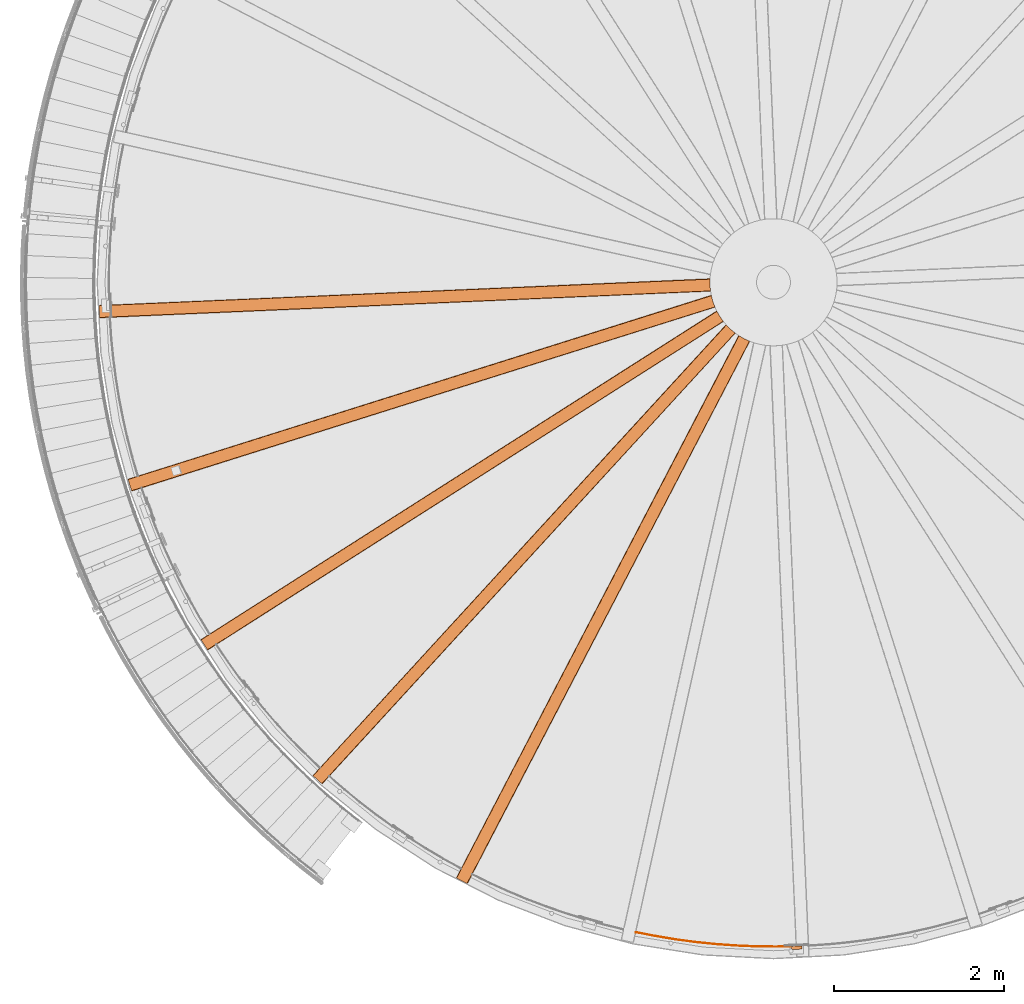
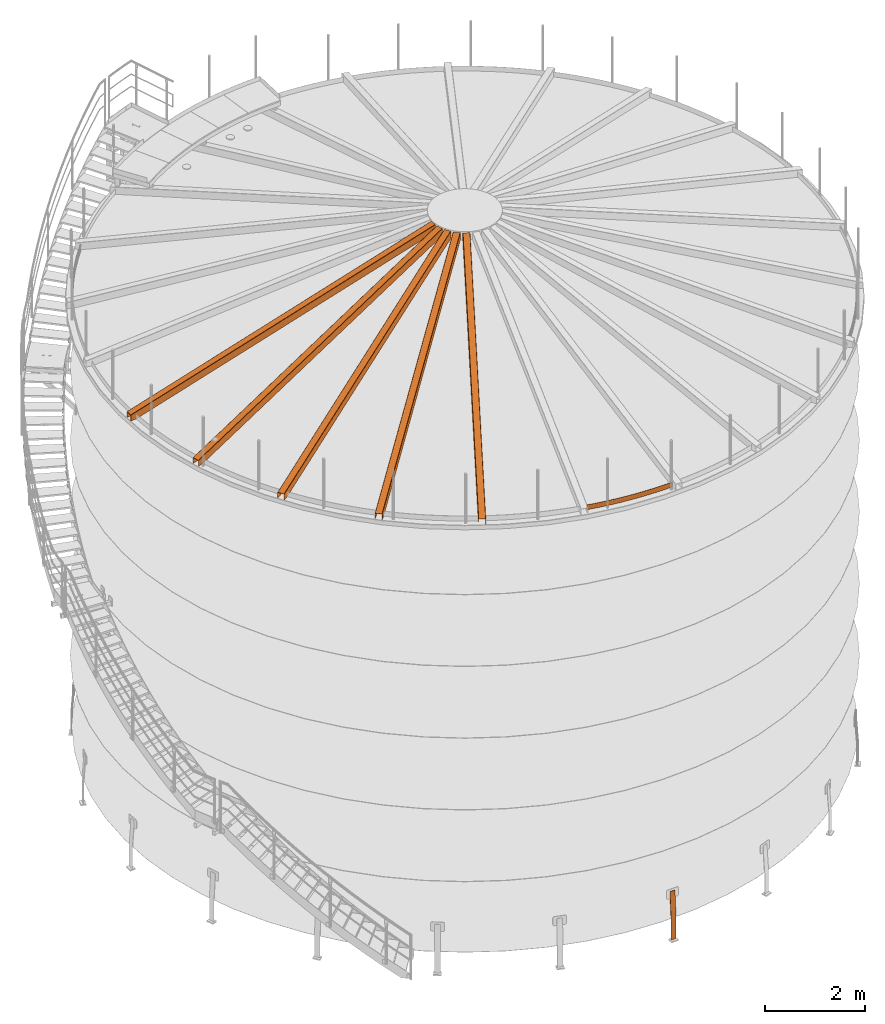
# One storey, part 15 of 126: 7 proxies.
"""IFC2X3 building model written with IfcOpenShell, lengths in millimetres."""

import ifcopenshell
import ifcopenshell.guid

model = None  # the IFC model being written
_history = None  # IfcOwnerHistory: only IFC2X3 demands one
_inside = {}  # id of a spatial element -> (the spatial element, [elements in it])
_under = {}  # id of a project, library or spatial element -> (it, [spatial elements below it])
_declared = {}  # id of a project -> (the project, [libraries it declares])
_typed = {}  # id of a type object -> (the type object, [elements of that type])
_made_of = {}  # id of a material, layer set ... -> (it, [elements and type objects made of it])


def new_model(schema):
    """Start an empty IFC model of exactly this schema.

    Asked for "IFC4X3", IfcOpenShell would pick the latest addendum, in which some entities
    have other attributes; the version numbers below select the first issue.
    IFC2X3 requires an IfcOwnerHistory on every rooted entity: one is made here for all.
    """
    global model, _history
    if schema == "IFC4X3":
        model = ifcopenshell.file(schema_version=(4, 3, 0, 0))
    else:
        model = ifcopenshell.file(schema=schema)
    _inside.clear()
    _under.clear()
    _declared.clear()
    _typed.clear()
    _made_of.clear()
    _history = None
    if model.schema == "IFC2X3":
        org = make("IfcOrganization", Name="unknown")
        user = make(
            "IfcPersonAndOrganization",
            ThePerson=make("IfcPerson", FamilyName="unknown"),
            TheOrganization=org,
        )
        app = make(
            "IfcApplication",
            ApplicationDeveloper=org,
            Version="unknown",
            ApplicationFullName="unknown",
            ApplicationIdentifier="unknown",
        )
        _history = make(
            "IfcOwnerHistory",
            OwningUser=user,
            OwningApplication=app,
            ChangeAction="ADDED",
            CreationDate=0,
        )
    return model


def make(cls, **values):
    """One entity of the class cls with the attributes given. An attribute that is None is left unset."""
    return model.create_entity(
        cls, **{name: value for name, value in values.items() if value is not None}
    )


def rooted(cls, **values):
    """An entity with a GlobalId (a new one), such as an element, a storey or a relation."""
    return make(cls, GlobalId=ifcopenshell.guid.new(), OwnerHistory=_history, **values)


def si_unit(unit_type, name, prefix=None):
    """IfcSIUnit, for example si_unit("LENGTHUNIT", "METRE", prefix="MILLI")."""
    return make("IfcSIUnit", UnitType=unit_type, Prefix=prefix, Name=name)


def assignment(units):
    """IfcUnitAssignment: the units of a project."""
    return None if units is None else make("IfcUnitAssignment", Units=units)


def point(xyz):
    """IfcCartesianPoint."""
    return None if xyz is None else make("IfcCartesianPoint", Coordinates=xyz)


def direction(xyz):
    """IfcDirection."""
    return None if xyz is None else make("IfcDirection", DirectionRatios=xyz)


def frame(location, z_axis=None, x_axis=None):
    """IfcAxis2Placement3D, a coordinate frame: its origin and axes. An axis left out is left unset."""
    return make(
        "IfcAxis2Placement3D",
        Location=point(location),
        Axis=direction(z_axis),
        RefDirection=direction(x_axis),
    )


def origin():
    """The frame at (0, 0, 0) with its axes left unset."""
    return frame((0.0, 0.0, 0.0))


def origin_with_axes():
    """The frame at (0, 0, 0) with the z axis (0, 0, 1) and the x axis (1, 0, 0) written out."""
    return frame((0.0, 0.0, 0.0), z_axis=(0.0, 0.0, 1.0), x_axis=(1.0, 0.0, 0.0))


def place(relative_to, where):
    """IfcLocalPlacement: puts the frame where relative to a parent placement (None: the world)."""
    return make(
        "IfcLocalPlacement", PlacementRelTo=relative_to, RelativePlacement=where
    )


def context(
    kind, dimensions, precision=None, world=None, true_north=None, identifier=None
):
    """IfcGeometricRepresentationContext, for example the 3D "Model" context."""
    return make(
        "IfcGeometricRepresentationContext",
        ContextIdentifier=identifier,
        ContextType=kind,
        CoordinateSpaceDimension=dimensions,
        Precision=precision,
        WorldCoordinateSystem=world,
        TrueNorth=true_north,
    )


def project(units=None, contexts=None):
    """IfcProject with its units and contexts."""
    return rooted(
        "IfcProject",
        Name="project",
        RepresentationContexts=contexts,
        UnitsInContext=assignment(units),
    )


def spatial(cls, under=None, at=None, **own):
    """A site, building, storey or space (cls), placed at a placement, below another one or the project."""
    s = rooted(cls, ObjectPlacement=at, **own)
    if under is not None:
        _under.setdefault(under.id(), (under, []))[1].append(s)
    return s


def faces_of(points, faces, orient=None, outer=None):
    """IfcFace entities. A face is a list of loops; a loop is a list of indices into points, from 0.

    orient and outer hold one flag for each loop. By default every Orientation is true, the
    first loop of a face is its IfcFaceOuterBound and the others are IfcFaceBound.
    """
    made = []
    for i, loops in enumerate(faces):
        bounds = []
        for j, loop in enumerate(loops):
            is_outer = j == 0 if outer is None else outer[i][j]
            bounds.append(
                make(
                    "IfcFaceOuterBound" if is_outer else "IfcFaceBound",
                    Bound=make("IfcPolyLoop", Polygon=[points[k] for k in loop]),
                    Orientation=True if orient is None else orient[i][j],
                )
            )
        made.append(make("IfcFace", Bounds=bounds))
    return made


def faceted_brep(points, faces, orient=None, outer=None, voids=None):
    """IfcFacetedBrep: a solid bounded by flat faces; with voids (closed shells), ...WithVoids."""
    shared = [point(p) for p in points]
    hull = make("IfcClosedShell", CfsFaces=faces_of(shared, faces, orient, outer))
    if voids is None:
        return make("IfcFacetedBrep", Outer=hull)
    return make(
        "IfcFacetedBrepWithVoids",
        Outer=hull,
        Voids=[
            make(cls, CfsFaces=faces_of(shared, fs, o, b)) for cls, fs, o, b in voids
        ],
    )


def shape(context_of_items, identifier, shape_type, items):
    """IfcShapeRepresentation: the items that make up one representation, for example the "Body"."""
    return make(
        "IfcShapeRepresentation",
        ContextOfItems=context_of_items,
        RepresentationIdentifier=identifier,
        RepresentationType=shape_type,
        Items=items,
    )


def material(Name=None, Category=None):
    """IfcMaterial."""
    return make("IfcMaterial", Name=Name, Category=Category)


def made_of(thing, what):
    """Note that an element or type object is made of a material, layer set ...; save() writes the relation."""
    if what is not None:
        _made_of.setdefault(what.id(), (what, []))[1].append(thing)
    return thing


def element(
    cls,
    number,
    at=None,
    inside=None,
    cuts=None,
    type_object=None,
    material=None,
    context=None,
    identifier="Body",
    shape_type=None,
    held_by="IfcProductDefinitionShape",
    body=None,
    shapes=None,
    **own,
):
    """One element of the class cls, such as IfcWall. Its Tag is "e" and its number.

    at: its placement. inside: the storey or other place that contains it. cuts: it is an
    opening in that element (IfcRelVoidsElement). A single representation is given by context,
    identifier, shape_type and body (its items); several are given by shapes. held_by: the class
    of the entity that holds the representations. save() writes the other relations.
    """
    e = rooted(cls, Tag="e%d" % number, ObjectPlacement=at, **own)
    if body is not None:
        shapes = [shape(context, identifier, shape_type, body)]
    if shapes is not None:
        e.Representation = make(held_by, Representations=shapes)
    if inside is not None:
        _inside.setdefault(inside.id(), (inside, []))[1].append(e)
    if cuts is not None:
        rooted(
            "IfcRelVoidsElement", RelatingBuildingElement=cuts, RelatedOpeningElement=e
        )
    if type_object is not None:
        _typed.setdefault(type_object.id(), (type_object, []))[1].append(e)
    return made_of(e, material)


def aggregate(whole, parts):
    """IfcRelAggregates: a whole, such as a stair, and the parts it consists of."""
    return rooted("IfcRelAggregates", RelatingObject=whole, RelatedObjects=parts)


def save(model, path):
    """Write the relations noted so far, then the file.

    IfcRelAggregates (storeys below a building ...), IfcRelContainedInSpatialStructure (elements
    in a storey), IfcRelDefinesByType, IfcRelAssociatesMaterial and IfcRelDeclares: one each for
    every whole, place, type object, material and project.
    """
    for whole, parts in _under.values():
        aggregate(whole, parts)
    for where, things in _inside.values():
        rooted(
            "IfcRelContainedInSpatialStructure",
            RelatedElements=things,
            RelatingStructure=where,
        )
    for kind, things in _typed.values():
        rooted("IfcRelDefinesByType", RelatedObjects=things, RelatingType=kind)
    for what, things in _made_of.values():
        rooted("IfcRelAssociatesMaterial", RelatedObjects=things, RelatingMaterial=what)
    for by, libraries in _declared.values():
        rooted("IfcRelDeclares", RelatingContext=by, RelatedDefinitions=libraries)
    model.write(path)


model = new_model("IFC2X3")

# Units and contexts
context_of_model_1 = context(None, 3, precision=0.1, world=origin())
context_of_model_2 = context(None, 3, precision=0.1, world=origin())
ifc_project = project(units=[si_unit("LENGTHUNIT", "METRE", prefix="MILLI"), si_unit("AREAUNIT", "SQUARE_METRE", prefix="CENTI"), si_unit("VOLUMEUNIT", "CUBIC_METRE", prefix="CENTI"), si_unit("MASSUNIT", "GRAM", prefix="KILO")], contexts=[context_of_model_1, context_of_model_2])

# Site, building, storey
site_placement = place(None, origin_with_axes())
site = spatial("IfcSite", under=ifc_project, at=site_placement, CompositionType="ELEMENT")
building_placement = place(site_placement, origin_with_axes())
building = spatial("IfcBuilding", under=site, at=building_placement, CompositionType="ELEMENT")
storey_placement = place(building_placement, origin_with_axes())
storey = spatial("IfcBuildingStorey", under=building, at=storey_placement, CompositionType="ELEMENT")

# Proxies
ifc_material = material(Name="STAHL")
proxy_1_placement = place(storey_placement, origin_with_axes())
element("IfcBuildingElementProxy", 1, at=proxy_1_placement, inside=storey, material=ifc_material, Name="profile", context=context_of_model_2, shape_type="Brep", body=[
    faceted_brep([(8224.3, 173.1, 654.1), (8224.0, 181.1, 654.1), (8221.6, 181.0, 651.1), (8221.8, 173.0, 651.1), (8219.7, 180.9, 647.7), (8220.0, 172.9, 647.7), (8218.6, 180.9, 643.9), (8218.9, 172.9, 643.9), (8219.8, 134.9, -500.0), (8219.8, 134.9, 0.0), (8218.5, 172.9, 540.0), (8218.5, 172.9, 640.0), (8218.2, 180.9, 640.0), (8218.2, 180.9, 540.0), (8219.5, 142.9, 0.0), (8219.5, 142.9, -500.0), (8334.7, 185.0, 651.1), (8332.3, 184.9, 654.1), (8332.5, 176.9, 654.1), (8335.0, 177.0, 651.1), (8336.9, 177.0, 647.7), (8336.6, 185.0, 647.7), (8338.0, 177.1, 643.9), (8337.7, 185.1, 643.9), (8339.7, 139.1, 0.0), (8339.7, 139.1, -500.0), (8339.4, 147.1, -500.0), (8339.4, 147.1, 0.0), (8338.1, 185.1, 540.0), (8338.1, 185.1, 640.0), (8338.4, 177.1, 640.0), (8338.4, 177.1, 540.0), (8234.6, 173.4, 659.6), (8238.5, 173.6, 660.0), (8318.4, 176.4, 660.0), (8322.3, 176.5, 659.6), (8322.0, 184.5, 659.6), (8318.1, 184.4, 660.0), (8238.2, 181.6, 660.0), (8234.3, 181.4, 659.6), (8325.8, 184.6, 658.5), (8326.1, 176.6, 658.5), (8329.2, 184.8, 656.6), (8329.5, 176.8, 656.6), (8230.8, 173.3, 658.5), (8230.5, 181.3, 658.5), (8227.3, 173.2, 656.6), (8227.1, 181.2, 656.6)], [[[0, 1, 2, 3]], [[3, 2, 4, 5]], [[5, 4, 6, 7]], [[8, 9, 10, 11, 7, 6, 12, 13, 14, 15]], [[16, 17, 18, 19]], [[16, 19, 20, 21]], [[21, 20, 22, 23]], [[24, 25, 26, 27, 28, 29, 23, 22, 30, 31]], [[32, 33, 34, 35, 36, 37, 38, 39]], [[40, 36, 35, 41]], [[42, 40, 41, 43]], [[42, 43, 18, 17]], [[44, 32, 39, 45]], [[46, 44, 45, 47]], [[0, 46, 47, 1]], [[9, 8, 25, 24, 31, 30, 22, 20, 19, 18, 43, 41, 35, 34, 33, 32, 44, 46, 0, 3, 5, 7, 11, 10]], [[14, 13, 12, 6, 4, 2, 1, 47, 45, 39, 38, 37, 36, 40, 42, 17, 16, 21, 23, 29, 28, 27, 26, 15]], [[26, 25, 8, 15]]]),
])
proxy_2_placement = place(storey_placement, origin_with_axes())
element("IfcBuildingElementProxy", 2, at=proxy_2_placement, inside=storey, material=ifc_material, Name="profile", context=context_of_model_2, shape_type="Brep", body=[
    faceted_brep([(7262.6, 7898.5, 12406.2), (7262.0, 7902.5, 12406.1), (7262.0, 7902.5, 12573.8), (7262.0, 7902.6, 12574.5), (7262.0, 7902.7, 12575.2), (7262.0, 7903.1, 12576.0), (7261.9, 7903.5, 12576.6), (7261.8, 7904.1, 12577.1), (7261.7, 7904.7, 12577.5), (7261.6, 7905.5, 12577.8), (7261.5, 7906.5, 12577.9), (7255.7, 7972.3, 12577.1), (7255.8, 8040.4, 12577.9), (7255.9, 8040.8, 12577.9), (7255.9, 8041.2, 12577.8), (7255.9, 8042.1, 12577.6), (7256.0, 8042.8, 12577.1), (7256.0, 8043.4, 12576.5), (7256.0, 8043.9, 12575.8), (7256.0, 8044.2, 12574.9), (7256.0, 8044.4, 12573.9), (7256.0, 8044.4, 12406.2), (7256.3, 8048.4, 12406.3), (7256.3, 8048.4, 12574.0), (7256.2, 8048.3, 12575.4), (7256.2, 8047.9, 12576.8), (7256.2, 8047.2, 12578.2), (7256.1, 8046.3, 12579.5), (7256.1, 8045.2, 12580.5), (7256.0, 8043.9, 12581.3), (7255.9, 8042.2, 12581.9), (7255.8, 8040.4, 12582.1), (7255.7, 7972.3, 12581.2), (7261.5, 7906.5, 12582.0), (7261.6, 7905.6, 12582.0), (7261.7, 7904.7, 12581.8), (7262.0, 7903.1, 12581.3), (7262.2, 7901.6, 12580.4), (7262.3, 7900.4, 12579.2), (7262.5, 7899.5, 12577.8), (7262.6, 7898.8, 12576.0), (7262.6, 7898.5, 12573.9), (55.8, 7583.9, 10506.0), (55.8, 7583.9, 10641.0), (55.8, 7584.0, 10642.6), (55.8, 7584.5, 10644.2), (55.7, 7585.4, 10645.9), (55.7, 7586.7, 10647.3), (55.6, 7588.2, 10648.4), (55.5, 7590.0, 10649.1), (55.5, 7591.9, 10649.3), (49.6, 7725.7, 10649.3), (49.5, 7727.3, 10649.2), (49.5, 7728.8, 10648.7), (49.4, 7730.4, 10647.7), (49.3, 7731.8, 10646.4), (49.3, 7732.8, 10644.8), (49.3, 7733.5, 10643.0), (49.3, 7733.7, 10641.0), (49.3, 7733.7, 10506.0), (49.4, 7729.7, 10506.0), (49.4, 7729.7, 10641.0), (49.4, 7729.6, 10641.8), (49.4, 7729.4, 10642.6), (49.5, 7729.0, 10643.5), (49.5, 7728.3, 10644.2), (49.5, 7727.5, 10644.7), (49.6, 7726.7, 10645.1), (49.6, 7725.7, 10645.2), (55.5, 7591.9, 10645.2), (55.5, 7591.1, 10645.1), (55.5, 7590.3, 10644.9), (55.6, 7589.5, 10644.4), (55.6, 7588.8, 10643.7), (55.6, 7588.3, 10642.9), (55.6, 7588.0, 10642.0), (55.6, 7587.9, 10641.0), (55.6, 7587.9, 10506.0), (171.3, 7735.0, 10506.0), (171.1, 7739.0, 10506.0), (177.7, 7589.2, 10506.0), (177.5, 7593.2, 10506.0)], [[[0, 1, 2, 3, 4, 5, 6, 7, 8, 9, 10, 11, 12, 13, 14, 15, 16, 17, 18, 19, 20, 21, 22, 23, 24, 25, 26, 27, 28, 29, 30, 31, 32, 33, 34, 35, 36, 37, 38, 39, 40, 41]], [[42, 43, 44, 45, 46, 47, 48, 49, 50, 51, 52, 53, 54, 55, 56, 57, 58, 59, 60, 61, 62, 63, 64, 65, 66, 67, 68, 69, 70, 71, 72, 73, 74, 75, 76, 77]], [[21, 78, 79, 22]], [[57, 24, 23, 22, 79, 59, 58]], [[56, 26, 25, 24, 57]], [[26, 56, 55, 27]], [[27, 55, 54, 28]], [[29, 28, 54, 53]], [[30, 29, 53, 52]], [[49, 35, 34, 33, 32, 31, 30, 52, 51, 50]], [[36, 35, 49, 48]], [[37, 36, 48, 47]], [[38, 37, 47, 46]], [[39, 38, 46, 45]], [[40, 39, 45, 44]], [[43, 42, 80, 0, 41, 40, 44]], [[1, 0, 80, 81]], [[77, 81, 80, 42]], [[60, 59, 79, 78]], [[62, 61, 60, 78, 21, 20, 19]], [[19, 18, 63, 62]], [[18, 17, 64, 63]], [[17, 16, 65, 64]], [[16, 15, 66, 65]], [[15, 14, 67, 66]], [[70, 69, 68, 67, 14, 13, 12, 11, 10, 9]], [[9, 8, 71, 70]], [[8, 7, 72, 71]], [[6, 73, 72, 7]], [[5, 74, 73, 6]], [[75, 74, 5, 4, 3]], [[77, 76, 75, 3, 2, 1, 81]]]),
])
proxy_3_placement = place(storey_placement, origin_with_axes())
element("IfcBuildingElementProxy", 3, at=proxy_3_placement, inside=storey, material=ifc_material, Name="profile", context=context_of_model_2, shape_type="Brep", body=[
    faceted_brep([(7315.5, 7710.0, 12406.2), (7313.9, 7713.7, 12406.1), (7313.9, 7713.7, 12573.8), (7313.9, 7713.8, 12574.5), (7313.8, 7713.9, 12575.2), (7313.7, 7714.2, 12576.0), (7313.5, 7714.7, 12576.6), (7313.3, 7715.2, 12577.1), (7313.0, 7715.8, 12577.5), (7312.7, 7716.5, 12577.8), (7312.3, 7717.4, 12577.9), (7289.7, 7779.5, 12577.1), (7272.2, 7845.3, 12577.9), (7272.1, 7845.7, 12577.9), (7272.0, 7846.1, 12577.8), (7271.8, 7846.9, 12577.6), (7271.7, 7847.7, 12577.1), (7271.6, 7848.2, 12576.5), (7271.5, 7848.7, 12575.8), (7271.4, 7849.1, 12574.9), (7271.4, 7849.2, 12573.9), (7271.4, 7849.2, 12406.2), (7270.5, 7853.1, 12406.3), (7270.5, 7853.1, 12574.0), (7270.6, 7853.0, 12575.4), (7270.6, 7852.6, 12576.8), (7270.8, 7852.0, 12578.2), (7271.0, 7851.1, 12579.5), (7271.2, 7850.0, 12580.5), (7271.5, 7848.7, 12581.3), (7271.8, 7847.1, 12581.9), (7272.2, 7845.3, 12582.1), (7289.7, 7779.5, 12581.2), (7312.3, 7717.4, 12582.0), (7312.7, 7716.6, 12582.0), (7313.0, 7715.7, 12581.8), (7313.7, 7714.2, 12581.3), (7314.2, 7712.9, 12580.4), (7314.7, 7711.8, 12579.2), (7315.1, 7710.9, 12577.8), (7315.4, 7710.2, 12576.0), (7315.5, 7710.0, 12573.9), (435.7, 5540.8, 10506.0), (435.7, 5540.8, 10641.0), (435.6, 5541.0, 10642.6), (435.5, 5541.4, 10644.2), (435.2, 5542.3, 10645.9), (434.8, 5543.5, 10647.3), (434.4, 5545.0, 10648.4), (433.8, 5546.7, 10649.1), (433.3, 5548.4, 10649.3), (393.0, 5676.2, 10649.3), (392.5, 5677.7, 10649.2), (392.0, 5679.2, 10648.7), (391.6, 5680.7, 10647.7), (391.1, 5682.0, 10646.4), (390.8, 5683.0, 10644.8), (390.6, 5683.7, 10643.0), (390.6, 5683.9, 10641.0), (390.6, 5683.9, 10506.0), (391.8, 5680.0, 10506.0), (391.8, 5680.0, 10641.0), (391.8, 5680.0, 10641.8), (391.9, 5679.8, 10642.6), (392.0, 5679.3, 10643.5), (392.2, 5678.7, 10644.2), (392.4, 5678.0, 10644.7), (392.7, 5677.1, 10645.1), (393.0, 5676.2, 10645.2), (433.3, 5548.4, 10645.2), (433.5, 5547.7, 10645.1), (433.7, 5547.0, 10644.9), (434.0, 5546.2, 10644.4), (434.2, 5545.5, 10643.7), (434.3, 5545.0, 10642.9), (434.4, 5544.7, 10642.0), (434.5, 5544.6, 10641.0), (434.5, 5544.6, 10506.0), (508.1, 5716.7, 10506.0), (506.9, 5720.5, 10506.0), (552.0, 5577.5, 10506.0), (550.8, 5581.3, 10506.0)], [[[0, 1, 2, 3, 4, 5, 6, 7, 8, 9, 10, 11, 12, 13, 14, 15, 16, 17, 18, 19, 20, 21, 22, 23, 24, 25, 26, 27, 28, 29, 30, 31, 32, 33, 34, 35, 36, 37, 38, 39, 40, 41]], [[42, 43, 44, 45, 46, 47, 48, 49, 50, 51, 52, 53, 54, 55, 56, 57, 58, 59, 60, 61, 62, 63, 64, 65, 66, 67, 68, 69, 70, 71, 72, 73, 74, 75, 76, 77]], [[21, 78, 79, 22]], [[57, 24, 23, 22, 79, 59, 58]], [[56, 26, 25, 24, 57]], [[26, 56, 55, 27]], [[27, 55, 54, 28]], [[29, 28, 54, 53]], [[30, 29, 53, 52]], [[49, 35, 34, 33, 32, 31, 30, 52, 51, 50]], [[36, 35, 49, 48]], [[37, 36, 48, 47]], [[38, 37, 47, 46]], [[39, 38, 46, 45]], [[40, 39, 45, 44]], [[43, 42, 80, 0, 41, 40, 44]], [[1, 0, 80, 81]], [[77, 81, 80, 42]], [[60, 59, 79, 78]], [[62, 61, 60, 78, 21, 20, 19]], [[19, 18, 63, 62]], [[18, 17, 64, 63]], [[17, 16, 65, 64]], [[16, 15, 66, 65]], [[15, 14, 67, 66]], [[70, 69, 68, 67, 14, 13, 12, 11, 10, 9]], [[9, 8, 71, 70]], [[8, 7, 72, 71]], [[6, 73, 72, 7]], [[5, 74, 73, 6]], [[75, 74, 5, 4, 3]], [[77, 76, 75, 3, 2, 1, 81]]]),
])
proxy_4_placement = place(storey_placement, origin_with_axes())
element("IfcBuildingElementProxy", 4, at=proxy_4_placement, inside=storey, material=ifc_material, Name="profile", context=context_of_model_2, shape_type="Brep", body=[
    faceted_brep([(7415.3, 7541.6, 12573.9), (7415.3, 7541.6, 12406.2), (7412.8, 7544.7, 12406.1), (7412.8, 7544.7, 12573.8), (7412.8, 7544.8, 12574.5), (7412.7, 7544.9, 12575.2), (7412.5, 7545.2, 12576.0), (7412.2, 7545.6, 12576.6), (7411.9, 7546.0, 12577.1), (7411.4, 7546.5, 12577.5), (7410.9, 7547.2, 12577.8), (7410.4, 7547.9, 12577.9), (7372.5, 7602.0, 12577.1), (7338.5, 7661.0, 12577.9), (7338.3, 7661.4, 12577.9), (7338.1, 7661.8, 12577.8), (7337.7, 7662.6, 12577.6), (7337.4, 7663.2, 12577.1), (7337.1, 7663.8, 12576.5), (7336.9, 7664.2, 12575.8), (7336.8, 7664.5, 12574.9), (7336.7, 7664.6, 12573.9), (7336.7, 7664.6, 12406.2), (7334.9, 7668.2, 12406.3), (7334.9, 7668.2, 12574.0), (7334.9, 7668.1, 12575.4), (7335.1, 7667.8, 12576.8), (7335.4, 7667.2, 12578.2), (7335.8, 7666.3, 12579.5), (7336.3, 7665.4, 12580.5), (7336.9, 7664.2, 12581.3), (7337.7, 7662.7, 12581.9), (7338.5, 7661.0, 12582.1), (7372.5, 7602.0, 12581.2), (7410.4, 7547.9, 12582.0), (7410.9, 7547.2, 12582.0), (7411.5, 7546.5, 12581.8), (7412.5, 7545.2, 12581.3), (7413.4, 7544.0, 12580.4), (7414.1, 7543.1, 12579.2), (7414.7, 7542.3, 12577.8), (7415.1, 7541.8, 12576.0), (1331.4, 3665.7, 10506.0), (1331.4, 3665.7, 10641.0), (1331.3, 3665.8, 10642.6), (1331.0, 3666.2, 10644.2), (1330.5, 3667.0, 10645.9), (1329.9, 3668.0, 10647.3), (1329.0, 3669.4, 10648.4), (1328.1, 3670.9, 10649.1), (1327.1, 3672.4, 10649.3), (1255.1, 3785.4, 10649.3), (1254.2, 3786.8, 10649.2), (1253.4, 3788.0, 10648.7), (1252.5, 3789.4, 10647.7), (1251.8, 3790.6, 10646.4), (1251.2, 3791.5, 10644.8), (1250.9, 3792.0, 10643.0), (1250.8, 3792.2, 10641.0), (1250.8, 3792.2, 10506.0), (1252.9, 3788.8, 10506.0), (1252.9, 3788.8, 10641.0), (1253.0, 3788.8, 10641.8), (1253.1, 3788.6, 10642.6), (1253.3, 3788.2, 10643.5), (1253.7, 3787.6, 10644.2), (1254.1, 3787.0, 10644.7), (1254.6, 3786.2, 10645.1), (1255.1, 3785.4, 10645.2), (1327.1, 3672.4, 10645.2), (1327.5, 3671.8, 10645.1), (1327.9, 3671.1, 10644.9), (1328.3, 3670.4, 10644.4), (1328.7, 3669.9, 10643.7), (1329.0, 3669.4, 10642.9), (1329.2, 3669.2, 10642.0), (1329.2, 3669.1, 10641.0), (1329.2, 3669.1, 10506.0), (1355.8, 3854.4, 10506.0), (1353.6, 3857.7, 10506.0), (1434.2, 3731.2, 10506.0), (1432.1, 3734.6, 10506.0)], [[[0, 1, 2, 3, 4, 5, 6, 7, 8, 9, 10, 11, 12, 13, 14, 15, 16, 17, 18, 19, 20, 21, 22, 23, 24, 25, 26, 27, 28, 29, 30, 31, 32, 33, 34, 35, 36, 37, 38, 39, 40, 41]], [[42, 43, 44, 45, 46, 47, 48, 49, 50, 51, 52, 53, 54, 55, 56, 57, 58, 59, 60, 61, 62, 63, 64, 65, 66, 67, 68, 69, 70, 71, 72, 73, 74, 75, 76, 77]], [[22, 78, 79, 23]], [[57, 25, 24, 23, 79, 59, 58]], [[56, 27, 26, 25, 57]], [[27, 56, 55, 28]], [[28, 55, 54, 29]], [[30, 29, 54, 53]], [[31, 30, 53, 52]], [[49, 36, 35, 34, 33, 32, 31, 52, 51, 50]], [[37, 36, 49, 48]], [[38, 37, 48, 47]], [[39, 38, 47, 46]], [[40, 39, 46, 45]], [[41, 40, 45, 44]], [[43, 42, 80, 1, 0, 41, 44]], [[2, 1, 80, 81]], [[77, 81, 80, 42]], [[60, 59, 79, 78]], [[61, 60, 78, 22, 21, 20, 62]], [[20, 19, 63, 62]], [[19, 18, 64, 63]], [[18, 17, 65, 64]], [[17, 16, 66, 65]], [[16, 15, 67, 66]], [[70, 69, 68, 67, 15, 14, 13, 12, 11, 10]], [[10, 9, 71, 70]], [[9, 8, 72, 71]], [[7, 73, 72, 8]], [[6, 74, 73, 7]], [[75, 74, 6, 5, 4]], [[77, 76, 75, 4, 3, 2, 81]]]),
])
proxy_5_placement = place(storey_placement, origin_with_axes())
element("IfcBuildingElementProxy", 5, at=proxy_5_placement, inside=storey, material=ifc_material, Name="profile", context=context_of_model_2, shape_type="Brep", body=[
    faceted_brep([(7555.3, 7404.7, 12406.2), (7552.1, 7407.2, 12406.1), (7552.1, 7407.2, 12573.8), (7552.1, 7407.2, 12574.5), (7551.9, 7407.3, 12575.2), (7551.7, 7407.5, 12576.0), (7551.3, 7407.8, 12576.6), (7550.9, 7408.1, 12577.1), (7550.3, 7408.5, 12577.5), (7549.7, 7409.0, 12577.8), (7548.9, 7409.6, 12577.9), (7498.3, 7452.0, 12577.1), (7450.3, 7500.3, 12577.9), (7450.0, 7500.6, 12577.9), (7449.7, 7500.9, 12577.8), (7449.1, 7501.5, 12577.6), (7448.6, 7502.1, 12577.1), (7448.2, 7502.5, 12576.5), (7447.9, 7502.9, 12575.8), (7447.7, 7503.1, 12574.9), (7447.6, 7503.2, 12573.9), (7447.6, 7503.2, 12406.2), (7444.9, 7506.2, 12406.3), (7444.9, 7506.2, 12574.0), (7445.0, 7506.1, 12575.4), (7445.2, 7505.9, 12576.8), (7445.7, 7505.4, 12578.2), (7446.3, 7504.7, 12579.5), (7447.0, 7503.9, 12580.5), (7447.9, 7502.9, 12581.3), (7449.0, 7501.6, 12581.9), (7450.3, 7500.3, 12582.1), (7498.3, 7452.0, 12581.2), (7548.9, 7409.6, 12582.0), (7549.6, 7409.1, 12582.0), (7550.4, 7408.5, 12581.8), (7551.7, 7407.5, 12581.3), (7552.8, 7406.6, 12580.4), (7553.8, 7405.9, 12579.2), (7554.6, 7405.3, 12577.8), (7555.1, 7404.9, 12576.0), (7555.3, 7404.7, 12573.9), (2681.9, 2086.3, 10506.0), (2681.9, 2086.3, 10641.0), (2681.7, 2086.4, 10642.6), (2681.4, 2086.7, 10644.2), (2680.7, 2087.3, 10645.9), (2679.8, 2088.2, 10647.3), (2678.6, 2089.2, 10648.4), (2677.3, 2090.4, 10649.1), (2676.0, 2091.7, 10649.3), (2577.2, 2182.2, 10649.3), (2576.0, 2183.3, 10649.2), (2574.9, 2184.3, 10648.7), (2573.7, 2185.4, 10647.7), (2572.7, 2186.3, 10646.4), (2571.9, 2187.0, 10644.8), (2571.4, 2187.5, 10643.0), (2571.3, 2187.6, 10641.0), (2571.3, 2187.6, 10506.0), (2574.2, 2184.9, 10506.0), (2574.2, 2184.9, 10641.0), (2574.3, 2184.9, 10641.8), (2574.4, 2184.7, 10642.6), (2574.8, 2184.4, 10643.5), (2575.3, 2184.0, 10644.2), (2575.8, 2183.4, 10644.7), (2576.5, 2182.8, 10645.1), (2577.2, 2182.2, 10645.2), (2676.0, 2091.7, 10645.2), (2676.5, 2091.2, 10645.1), (2677.1, 2090.6, 10644.9), (2677.7, 2090.1, 10644.4), (2678.2, 2089.6, 10643.7), (2678.6, 2089.3, 10642.9), (2678.8, 2089.1, 10642.0), (2678.9, 2089.0, 10641.0), (2678.9, 2089.0, 10506.0), (2656.6, 2274.8, 10506.0), (2653.7, 2277.5, 10506.0), (2764.3, 2176.2, 10506.0), (2761.3, 2178.9, 10506.0)], [[[0, 1, 2, 3, 4, 5, 6, 7, 8, 9, 10, 11, 12, 13, 14, 15, 16, 17, 18, 19, 20, 21, 22, 23, 24, 25, 26, 27, 28, 29, 30, 31, 32, 33, 34, 35, 36, 37, 38, 39, 40, 41]], [[42, 43, 44, 45, 46, 47, 48, 49, 50, 51, 52, 53, 54, 55, 56, 57, 58, 59, 60, 61, 62, 63, 64, 65, 66, 67, 68, 69, 70, 71, 72, 73, 74, 75, 76, 77]], [[21, 78, 79, 22]], [[57, 24, 23, 22, 79, 59, 58]], [[55, 27, 26, 25, 24, 57, 56]], [[27, 55, 54, 28]], [[29, 28, 54, 53]], [[30, 29, 53, 52]], [[49, 35, 34, 33, 32, 31, 30, 52, 51, 50]], [[36, 35, 49, 48]], [[37, 36, 48, 47]], [[38, 37, 47, 46]], [[44, 40, 39, 38, 46, 45]], [[43, 42, 80, 0, 41, 40, 44]], [[1, 0, 80, 81]], [[77, 81, 80, 42]], [[60, 59, 79, 78]], [[61, 60, 78, 21, 20, 19, 62]], [[64, 63, 62, 19, 18, 17]], [[17, 16, 65, 64]], [[16, 15, 66, 65]], [[15, 14, 67, 66]], [[70, 69, 68, 67, 14, 13, 12, 11, 10, 9]], [[9, 8, 71, 70]], [[8, 7, 72, 71]], [[6, 73, 72, 7]], [[75, 74, 73, 6, 5, 4, 3]], [[77, 76, 75, 3, 2, 1, 81]]]),
])
proxy_6_placement = place(storey_placement, origin_with_axes())
element("IfcBuildingElementProxy", 6, at=proxy_6_placement, inside=storey, material=ifc_material, Name="profile", context=context_of_model_2, shape_type="Brep", body=[
    faceted_brep([(7726.0, 7308.8, 12573.9), (7726.0, 7308.8, 12406.2), (7722.3, 7310.3, 12406.1), (7722.3, 7310.3, 12573.8), (7722.2, 7310.3, 12574.5), (7722.1, 7310.4, 12575.2), (7721.8, 7310.5, 12576.0), (7721.3, 7310.7, 12576.6), (7720.8, 7310.9, 12577.1), (7720.2, 7311.2, 12577.5), (7719.4, 7311.5, 12577.8), (7718.6, 7311.8, 12577.9), (7658.7, 7339.7, 12577.1), (7599.8, 7373.9, 12577.9), (7599.4, 7374.1, 12577.9), (7599.0, 7374.4, 12577.8), (7598.4, 7374.8, 12577.6), (7597.7, 7375.2, 12577.1), (7597.2, 7375.5, 12576.5), (7596.8, 7375.8, 12575.8), (7596.5, 7376.0, 12574.9), (7596.4, 7376.1, 12573.9), (7596.4, 7376.1, 12406.2), (7593.1, 7378.3, 12406.3), (7593.1, 7378.3, 12574.0), (7593.2, 7378.2, 12575.4), (7593.5, 7378.0, 12576.8), (7594.0, 7377.6, 12578.2), (7594.8, 7377.1, 12579.5), (7595.7, 7376.5, 12580.5), (7596.8, 7375.8, 12581.3), (7598.2, 7374.9, 12581.9), (7599.8, 7373.9, 12582.1), (7658.7, 7339.7, 12581.2), (7718.6, 7311.8, 12582.0), (7719.4, 7311.5, 12582.0), (7720.2, 7311.2, 12581.8), (7721.8, 7310.5, 12581.3), (7723.1, 7310.0, 12580.4), (7724.2, 7309.5, 12579.2), (7725.1, 7309.2, 12577.8), (7725.8, 7308.9, 12576.0), (4395.1, 910.2, 10506.0), (4395.1, 910.2, 10641.0), (4395.0, 910.3, 10642.6), (4394.6, 910.5, 10644.2), (4393.8, 910.9, 10645.9), (4392.6, 911.5, 10647.3), (4391.2, 912.2, 10648.4), (4389.7, 913.1, 10649.1), (4388.0, 913.9, 10649.3), (4269.2, 975.8, 10649.3), (4267.8, 976.5, 10649.2), (4266.4, 977.2, 10648.7), (4265.0, 978.0, 10647.7), (4263.8, 978.6, 10646.4), (4262.8, 979.1, 10644.8), (4262.3, 979.4, 10643.0), (4262.1, 979.5, 10641.0), (4262.1, 979.5, 10506.0), (4265.6, 977.6, 10506.0), (4265.6, 977.6, 10641.0), (4265.7, 977.6, 10641.8), (4265.9, 977.5, 10642.6), (4266.3, 977.3, 10643.5), (4266.9, 977.0, 10644.2), (4267.6, 976.6, 10644.7), (4268.3, 976.2, 10645.1), (4269.2, 975.8, 10645.2), (4388.0, 913.9, 10645.2), (4388.7, 913.6, 10645.1), (4389.4, 913.2, 10644.9), (4390.1, 912.8, 10644.4), (4390.7, 912.5, 10643.7), (4391.2, 912.3, 10642.9), (4391.5, 912.1, 10642.0), (4391.6, 912.1, 10641.0), (4391.6, 912.1, 10506.0), (4321.9, 1085.8, 10506.0), (4318.4, 1087.7, 10506.0), (4451.4, 1018.4, 10506.0), (4447.9, 1020.3, 10506.0)], [[[0, 1, 2, 3, 4, 5, 6, 7, 8, 9, 10, 11, 12, 13, 14, 15, 16, 17, 18, 19, 20, 21, 22, 23, 24, 25, 26, 27, 28, 29, 30, 31, 32, 33, 34, 35, 36, 37, 38, 39, 40, 41]], [[42, 43, 44, 45, 46, 47, 48, 49, 50, 51, 52, 53, 54, 55, 56, 57, 58, 59, 60, 61, 62, 63, 64, 65, 66, 67, 68, 69, 70, 71, 72, 73, 74, 75, 76, 77]], [[22, 78, 79, 23]], [[57, 25, 24, 23, 79, 59, 58]], [[56, 27, 26, 25, 57]], [[27, 56, 55, 28]], [[28, 55, 54, 29]], [[30, 29, 54, 53]], [[31, 30, 53, 52]], [[49, 36, 35, 34, 33, 32, 31, 52, 51, 50]], [[37, 36, 49, 48]], [[38, 37, 48, 47]], [[39, 38, 47, 46]], [[40, 39, 46, 45]], [[41, 40, 45, 44]], [[43, 42, 80, 1, 0, 41, 44]], [[2, 1, 80, 81]], [[77, 81, 80, 42]], [[60, 59, 79, 78]], [[61, 60, 78, 22, 21, 20, 62]], [[20, 19, 63, 62]], [[19, 18, 64, 63]], [[18, 17, 65, 64]], [[17, 16, 66, 65]], [[16, 15, 67, 66]], [[70, 69, 68, 67, 15, 14, 13, 12, 11, 10]], [[10, 9, 71, 70]], [[9, 8, 72, 71]], [[7, 73, 72, 8]], [[6, 74, 73, 7]], [[75, 74, 6, 5, 4]], [[75, 4, 3, 2, 81, 77, 76]]]),
])
proxy_7_placement = place(storey_placement, origin_with_axes())
element("IfcBuildingElementProxy", 7, at=proxy_7_placement, inside=storey, material=ifc_material, Name="profile", context=context_of_model_2, shape_type="Brep", body=[
    faceted_brep([(8033.6, 165.2, 10516.0), (8271.5, 169.7, 10516.0), (8271.5, 169.7, 10636.0), (8033.6, 165.2, 10636.0), (7795.7, 167.9, 10636.0), (7558.0, 177.9, 10636.0), (7320.7, 195.1, 10636.0), (7084.1, 219.4, 10636.0), (6848.2, 251.0, 10636.0), (6613.5, 289.6, 10636.0), (6380.0, 335.4, 10636.0), (6380.0, 335.4, 10516.0), (6613.5, 289.6, 10516.0), (6848.2, 251.0, 10516.0), (7084.1, 219.4, 10516.0), (7320.7, 195.1, 10516.0), (7558.0, 177.9, 10516.0), (7795.7, 167.9, 10516.0), (8271.3, 174.7, 10636.0), (8033.6, 170.2, 10636.0), (7795.9, 172.9, 10636.0), (7558.3, 182.9, 10636.0), (7321.2, 200.0, 10636.0), (7084.6, 224.4, 10636.0), (6849.0, 255.9, 10636.0), (6614.4, 294.5, 10636.0), (6381.0, 340.3, 10636.0), (8271.3, 174.7, 10516.0), (8033.6, 170.2, 10516.0), (7795.9, 172.9, 10516.0), (7558.3, 182.9, 10516.0), (7321.2, 200.0, 10516.0), (7084.6, 224.4, 10516.0), (6849.0, 255.9, 10516.0), (6614.4, 294.5, 10516.0), (6381.0, 340.3, 10516.0)], [[[0, 1, 2, 3, 4, 5, 6, 7, 8, 9, 10, 11, 12, 13, 14, 15, 16, 17]], [[3, 2, 18, 19, 20, 21, 22, 23, 24, 25, 26, 10, 9, 8, 7, 6, 5, 4]], [[19, 18, 27, 28, 29, 30, 31, 32, 33, 34, 35, 26, 25, 24, 23, 22, 21, 20]], [[0, 17, 16, 15, 14, 13, 12, 11, 35, 34, 33, 32, 31, 30, 29, 28, 27, 1]], [[18, 2, 1, 27]], [[10, 26, 35, 11]]]),
])

save(model, "model.ifc")
